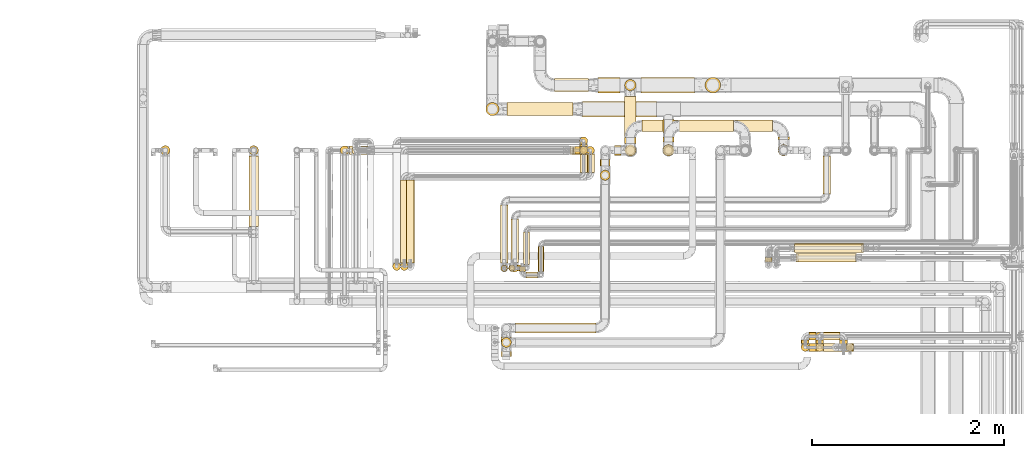
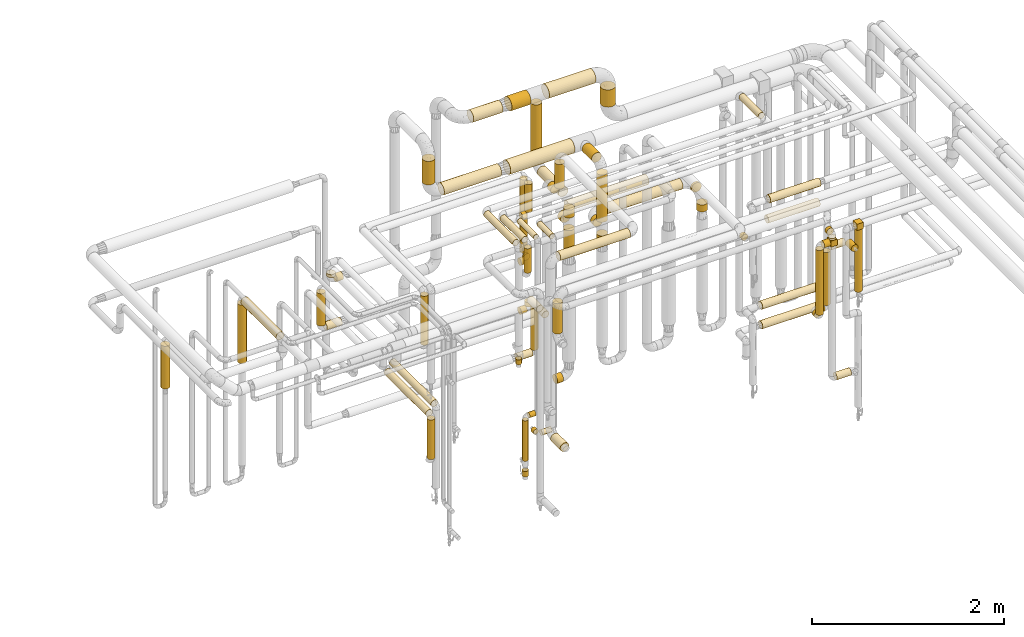
# One storey, part 17 of 824: 78 coverings.
"""IFC2X3 building model written with IfcOpenShell, lengths in millimetres."""

from ifc_helpers import new_model, entity, si_unit, converted_unit, derived_unit, direction, frame, origin, origin_2d_with_axis, place, context, subcontext, project, spatial, rectangle, circle, extrude, element, save


model = new_model("IFC2X3")

# Units and contexts
model_context = context("Model", 3, precision=0.01, world=origin(), true_north=direction((6.12303176911189e-17, 1.0)))
body_context = subcontext(model_context, "Body", "Model", "MODEL_VIEW")
ifc_project = project(units=[si_unit("LENGTHUNIT", "METRE", prefix="MILLI"), si_unit("AREAUNIT", "SQUARE_METRE"), si_unit("VOLUMEUNIT", "CUBIC_METRE"), converted_unit("PLANEANGLEUNIT", "DEGREE", entity("IfcRatioMeasure", 0.0174532925199433), si_unit("PLANEANGLEUNIT", "RADIAN"), dimensions=[0, 0, 0, 0, 0, 0, 0]), si_unit("MASSUNIT", "GRAM", prefix="KILO"), derived_unit("MASSDENSITYUNIT", [(si_unit("MASSUNIT", "GRAM", prefix="KILO"), 1), (si_unit("LENGTHUNIT", "METRE"), -3)]), derived_unit("MOMENTOFINERTIAUNIT", [(si_unit("LENGTHUNIT", "METRE"), 4)]), si_unit("TIMEUNIT", "SECOND"), si_unit("FREQUENCYUNIT", "HERTZ"), si_unit("THERMODYNAMICTEMPERATUREUNIT", "DEGREE_CELSIUS"), derived_unit("THERMALTRANSMITTANCEUNIT", [(si_unit("MASSUNIT", "GRAM", prefix="KILO"), 1), (si_unit("THERMODYNAMICTEMPERATUREUNIT", "KELVIN"), -1), (si_unit("TIMEUNIT", "SECOND"), -3)]), derived_unit("VOLUMETRICFLOWRATEUNIT", [(si_unit("LENGTHUNIT", "METRE"), 3), (si_unit("TIMEUNIT", "SECOND"), -1)]), derived_unit("MASSFLOWRATEUNIT", [(si_unit("MASSUNIT", "GRAM", prefix="KILO"), 1), (si_unit("TIMEUNIT", "SECOND"), -1)]), derived_unit("ROTATIONALFREQUENCYUNIT", [(si_unit("TIMEUNIT", "SECOND"), -1)]), si_unit("ELECTRICCURRENTUNIT", "AMPERE"), si_unit("ELECTRICVOLTAGEUNIT", "VOLT"), si_unit("POWERUNIT", "WATT"), si_unit("FORCEUNIT", "NEWTON", prefix="KILO"), si_unit("ILLUMINANCEUNIT", "LUX"), si_unit("LUMINOUSFLUXUNIT", "LUMEN"), si_unit("LUMINOUSINTENSITYUNIT", "CANDELA"), derived_unit("USERDEFINED", [(si_unit("MASSUNIT", "GRAM", prefix="KILO"), -1), (si_unit("LENGTHUNIT", "METRE"), -2), (si_unit("TIMEUNIT", "SECOND"), 3), (si_unit("LUMINOUSFLUXUNIT", "LUMEN"), 1)]), derived_unit("LINEARVELOCITYUNIT", [(si_unit("LENGTHUNIT", "METRE"), 1), (si_unit("TIMEUNIT", "SECOND"), -1)]), si_unit("PRESSUREUNIT", "PASCAL"), derived_unit("USERDEFINED", [(si_unit("LENGTHUNIT", "METRE"), -2), (si_unit("MASSUNIT", "GRAM", prefix="KILO"), 1), (si_unit("TIMEUNIT", "SECOND"), -2)]), derived_unit("LINEARFORCEUNIT", [(si_unit("MASSUNIT", "GRAM", prefix="KILO"), 1), (si_unit("LENGTHUNIT", "METRE"), 1), (si_unit("TIMEUNIT", "SECOND"), -2), (si_unit("LENGTHUNIT", "METRE"), -1)]), derived_unit("PLANARFORCEUNIT", [(si_unit("MASSUNIT", "GRAM", prefix="KILO"), 1), (si_unit("LENGTHUNIT", "METRE"), 1), (si_unit("TIMEUNIT", "SECOND"), -2), (si_unit("LENGTHUNIT", "METRE"), -2)])], contexts=[model_context])

# Site, building, storey
site_placement = place(None, origin())
site = spatial("IfcSite", under=ifc_project, at=site_placement, CompositionType="ELEMENT")
building_placement = place(site_placement, origin())
building = spatial("IfcBuilding", under=site, at=building_placement, CompositionType="ELEMENT")
storey_placement = place(building_placement, frame((0.0, 0.0, 28200.0)))
storey = spatial("IfcBuildingStorey", under=building, at=storey_placement, CompositionType="ELEMENT", Elevation=28200.0)

# Coverings
covering_1_placement = place(storey_placement, frame((53070.46, 17449.4, 1898.17)))
element("IfcCovering", 1, at=covering_1_placement, inside=storey, PredefinedType="INSULATION", context=body_context, shape_type="SweptSolid", body=[
    extrude(circle(Radius=49.0, at=origin_2d_with_axis()), frame((50.6, 50.6, 0.0), z_axis=(0.0, 0.0, 1.0), x_axis=(-1.0, 0.0, 0.0)), (0.0, 0.0, 1.0), 743.078196918212),
])
covering_2_placement = place(storey_placement, frame((52147.68, 17449.4, 1898.17)))
element("IfcCovering", 2, at=covering_2_placement, inside=storey, PredefinedType="INSULATION", context=body_context, shape_type="SweptSolid", body=[
    extrude(circle(Radius=49.0, at=origin_2d_with_axis()), frame((50.6, 50.6, 0.0), z_axis=(0.0, 0.0, 1.0), x_axis=(-1.0, 0.0, 0.0)), (0.0, 0.0, 1.0), 543.000000000011),
])
covering_3_placement = place(storey_placement, frame((53070.46, 16705.32, 2647.65)))
element("IfcCovering", 3, at=covering_3_placement, inside=storey, PredefinedType="INSULATION", context=body_context, shape_type="SweptSolid", body=[
    extrude(circle(Radius=49.0, at=origin_2d_with_axis()), frame((50.6, 0.07, 51.61), z_axis=(0.0, 0.999999057686602, -0.00137281677839978), x_axis=(1.0, 0.0, 0.0)), (0.0, 0.0, 1.0), 737.692684756272),
])
covering_4_placement = place(storey_placement, frame((57387.04, 17586.0, 2039.15)))
element("IfcCovering", 4, at=covering_4_placement, inside=storey, PredefinedType="INSULATION", context=body_context, shape_type="SweptSolid", body=[
    extrude(circle(Radius=59.25, at=origin_2d_with_axis()), frame((60.85, 0.0, 60.85), z_axis=(0.0, 1.0, 0.0), x_axis=(1.0, 0.0, 0.0)), (0.0, 0.0, 1.0), 55.0961141089978),
])
covering_5_placement = place(storey_placement, frame((57387.04, 17614.0, 2839.12)))
element("IfcCovering", 5, at=covering_5_placement, inside=storey, PredefinedType="INSULATION", context=body_context, shape_type="SweptSolid", body=[
    extrude(circle(Radius=59.25, at=origin_2d_with_axis()), frame((60.85, 0.0, 60.85), z_axis=(0.0, 1.0, 0.0), x_axis=(1.0, 0.0, 0.0)), (0.0, 0.0, 1.0), 205.096097794299),
])
covering_6_placement = place(storey_placement, frame((57387.04, 17439.15, 1915.45)))
element("IfcCovering", 6, at=covering_6_placement, inside=storey, PredefinedType="INSULATION", context=body_context, shape_type="SweptSolid", body=[
    extrude(circle(Radius=59.25, at=origin_2d_with_axis()), frame((60.85, 60.85, 0.0), z_axis=(0.0, 0.0, 1.0), x_axis=(-1.0, 0.0, 0.0)), (0.0, 0.0, 1.0), 98.5472224728106),
])
covering_7_placement = place(storey_placement, frame((57387.04, 17439.15, 2186.0)))
element("IfcCovering", 7, at=covering_7_placement, inside=storey, PredefinedType="INSULATION", context=body_context, shape_type="SweptSolid", body=[
    extrude(circle(Radius=59.25, at=origin_2d_with_axis()), frame((60.85, 60.85, 0.0), z_axis=(0.0, 0.0, 1.0), x_axis=(-1.0, 0.0, 0.0)), (0.0, 0.0, 1.0), 600.000000000011),
])
covering_8_placement = place(storey_placement, frame((58588.54, 17614.0, 2039.15)))
element("IfcCovering", 8, at=covering_8_placement, inside=storey, PredefinedType="INSULATION", context=body_context, shape_type="SweptSolid", body=[
    extrude(circle(Radius=59.25, at=origin_2d_with_axis()), frame((60.85, 0.0, 60.85), z_axis=(0.0, 1.0, 0.0), x_axis=(1.0, 0.0, 0.0)), (0.0, 0.0, 1.0), 27.0961141089868),
])
covering_9_placement = place(storey_placement, frame((58588.54, 17439.15, 1898.17)))
element("IfcCovering", 9, at=covering_9_placement, inside=storey, PredefinedType="INSULATION", context=body_context, shape_type="SweptSolid", body=[
    extrude(circle(Radius=59.25, at=origin_2d_with_axis()), frame((60.85, 60.85, 0.0)), (0.0, 0.0, 1.0), 87.8307333425285),
])
covering_10_placement = place(storey_placement, frame((59297.12, 15400.86, 1868.01)))
element("IfcCovering", 10, at=covering_10_placement, inside=storey, PredefinedType="INSULATION", context=body_context, shape_type="SweptSolid", body=[
    extrude(circle(Radius=41.75, at=origin_2d_with_axis()), frame((43.35, 43.35, 0.0), z_axis=(0.0, 0.0, 1.0), x_axis=(0.0, -1.0, 0.0)), (0.0, 0.0, 1.0), 793.987023342036),
])
covering_11_placement = place(storey_placement, frame((59302.46, 15402.36, 2662.0)))
element("IfcCovering", 11, at=covering_11_placement, inside=storey, PredefinedType="INSULATION", context=body_context, shape_type="SweptSolid", body=[
    extrude(rectangle(XDim=75.9999999999914, YDim=83.7000000000026, at=origin_2d_with_axis()), frame((38.0, 41.85, 0.0)), (0.0, 0.0, 1.0), 79.8499999999992),
])
covering_12_placement = place(storey_placement, frame((58981.79, 15482.21, 2656.65)))
element("IfcCovering", 12, at=covering_12_placement, inside=storey, PredefinedType="INSULATION", context=body_context, shape_type="SweptSolid", body=[
    extrude(circle(Radius=41.75, at=origin_2d_with_axis()), frame((43.35, 0.0, 43.35), z_axis=(0.0, 1.0, 0.0), x_axis=(1.0, 0.0, 0.0)), (0.0, 0.0, 1.0), 40.3142874709578),
])
covering_13_placement = place(storey_placement, frame((59063.14, 15400.86, 827.17)))
element("IfcCovering", 13, at=covering_13_placement, inside=storey, PredefinedType="INSULATION", context=body_context, shape_type="SweptSolid", body=[
    extrude(circle(Radius=41.75, at=origin_2d_with_axis()), frame((0.0, 43.35, 43.35), z_axis=(1.0, 0.0, 0.0), x_axis=(0.0, 1.0, 0.0)), (0.0, 0.0, 1.0), 172.217361032213),
])
covering_14_placement = place(storey_placement, frame((58911.89, 15400.86, 2556.65)))
element("IfcCovering", 14, at=covering_14_placement, inside=storey, PredefinedType="INSULATION", context=body_context, shape_type="SweptSolid", body=[
    extrude(circle(Radius=41.75, at=origin_2d_with_axis()), frame((0.0, 43.35, 43.35), z_axis=(1.0, 0.0, 0.0), x_axis=(0.0, -1.0, 0.0)), (0.0, 0.0, 1.0), 75.2500000000219),
])
covering_15_placement = place(storey_placement, frame((58987.14, 15402.36, 2562.0)))
element("IfcCovering", 15, at=covering_15_placement, inside=storey, PredefinedType="INSULATION", context=body_context, shape_type="SweptSolid", body=[
    extrude(rectangle(XDim=79.8500000000035, YDim=83.7000000000026, at=origin_2d_with_axis()), frame((39.93, 41.85, 0.0)), (0.0, 0.0, 1.0), 75.9999999999957),
])
covering_16_placement = place(storey_placement, frame((58981.79, 15400.86, 2638.0)))
element("IfcCovering", 16, at=covering_16_placement, inside=storey, PredefinedType="INSULATION", context=body_context, shape_type="SweptSolid", body=[
    extrude(circle(Radius=41.75, at=origin_2d_with_axis()), frame((43.35, 43.35, 0.0)), (0.0, 0.0, 1.0), 24.0000000000075),
])
covering_17_placement = place(storey_placement, frame((58830.54, 15400.86, 1738.53)))
element("IfcCovering", 17, at=covering_17_placement, inside=storey, PredefinedType="INSULATION", context=body_context, shape_type="SweptSolid", body=[
    extrude(circle(Radius=41.75, at=origin_2d_with_axis()), frame((43.35, 43.35, 0.0)), (0.0, 0.0, 1.0), 823.470090868733),
])
covering_18_placement = place(storey_placement, frame((58830.54, 15482.21, 1657.18)))
element("IfcCovering", 18, at=covering_18_placement, inside=storey, PredefinedType="INSULATION", context=body_context, shape_type="SweptSolid", body=[
    extrude(circle(Radius=41.75, at=origin_2d_with_axis()), frame((43.35, 0.0, 43.35), z_axis=(0.0, 1.0, 0.0), x_axis=(-1.0, 0.0, 0.0)), (0.0, 0.0, 1.0), 40.2592236656059),
])
covering_19_placement = place(storey_placement, frame((58911.89, 15517.12, 1657.18)))
element("IfcCovering", 19, at=covering_19_placement, inside=storey, PredefinedType="INSULATION", context=body_context, shape_type="SweptSolid", body=[
    extrude(circle(Radius=41.75, at=origin_2d_with_axis()), frame((0.0, 43.35, 43.35), z_axis=(1.0, 0.0, 0.0), x_axis=(0.0, 1.0, 0.0)), (0.0, 0.0, 1.0), 74.0000000000178),
])
covering_20_placement = place(storey_placement, frame((58980.54, 15517.12, 1738.53)))
element("IfcCovering", 20, at=covering_20_placement, inside=storey, PredefinedType="INSULATION", context=body_context, shape_type="SweptSolid", body=[
    extrude(circle(Radius=41.75, at=origin_2d_with_axis()), frame((43.35, 43.35, 0.0), z_axis=(0.0, 0.0, 1.0), x_axis=(0.0, 1.0, 0.0)), (0.0, 0.0, 1.0), 674.000039895076),
])
covering_21_placement = place(storey_placement, frame((59061.89, 15517.18, 2407.18)))
element("IfcCovering", 21, at=covering_21_placement, inside=storey, PredefinedType="INSULATION", context=body_context, shape_type="SweptSolid", body=[
    extrude(circle(Radius=41.75, at=origin_2d_with_axis()), frame((0.0, 43.35, 43.35), z_axis=(1.0, 0.0, 0.0), x_axis=(0.0, 1.0, 0.0)), (0.0, 0.0, 1.0), 173.467361032217),
])
covering_22_placement = place(storey_placement, frame((59230.01, 15402.52, 2407.18)))
element("IfcCovering", 22, at=covering_22_placement, inside=storey, PredefinedType="INSULATION", context=body_context, shape_type="SweptSolid", body=[
    extrude(circle(Radius=41.75, at=origin_2d_with_axis()), frame((43.35, 0.0, 43.35), z_axis=(0.0, 1.0, 0.0), x_axis=(1.0, 0.0, 0.0)), (0.0, 0.0, 1.0), 119.99999999999),
])
covering_23_placement = place(storey_placement, frame((56551.05, 17847.0, 2816.87)))
element("IfcCovering", 23, at=covering_23_placement, inside=storey, PredefinedType="INSULATION", context=body_context, shape_type="SweptSolid", body=[
    extrude(circle(Radius=81.5, at=origin_2d_with_axis()), frame((0.0, 83.1, 83.1), z_axis=(1.0, 0.0, 0.0), x_axis=(0.0, -1.0, 0.0)), (0.0, 0.0, 1.0), 772.836562103827),
])
covering_24_placement = place(storey_placement, frame((55761.05, 17859.5, 2829.37)))
element("IfcCovering", 24, at=covering_24_placement, inside=storey, PredefinedType="INSULATION", context=body_context, shape_type="SweptSolid", body=[
    extrude(circle(Radius=69.0, at=origin_2d_with_axis()), frame((0.0, 70.6, 70.6), z_axis=(1.0, 0.0, 0.0), x_axis=(0.0, -1.0, 0.0)), (0.0, 0.0, 1.0), 690.000000000068),
])
covering_25_placement = place(storey_placement, frame((55540.45, 17859.5, 3049.96)))
element("IfcCovering", 25, at=covering_25_placement, inside=storey, PredefinedType="INSULATION", context=body_context, shape_type="SweptSolid", body=[
    extrude(circle(Radius=69.0, at=origin_2d_with_axis()), frame((70.6, 70.6, 0.0), z_axis=(0.0, 0.0, 1.0), x_axis=(0.0, -1.0, 0.0)), (0.0, 0.0, 1.0), 299.782089013241),
])
covering_26_placement = place(storey_placement, frame((57561.89, 17694.25, 2039.15)))
element("IfcCovering", 26, at=covering_26_placement, inside=storey, PredefinedType="INSULATION", context=body_context, shape_type="SweptSolid", body=[
    extrude(circle(Radius=59.25, at=origin_2d_with_axis()), frame((0.0, 60.85, 60.85), z_axis=(1.0, 0.0, 0.0), x_axis=(0.0, 1.0, 0.0)), (0.0, 0.0, 1.0), 973.496500000027),
])
covering_27_placement = place(storey_placement, frame((56519.88, 17456.65, 2605.5)))
element("IfcCovering", 27, at=covering_27_placement, inside=storey, PredefinedType="INSULATION", context=body_context, shape_type="SweptSolid", body=[
    extrude(circle(Radius=41.75, at=origin_2d_with_axis()), frame((43.35, 43.35, 0.0), z_axis=(0.0, 0.0, 1.0), x_axis=(0.0, -1.0, 0.0)), (0.0, 0.0, 1.0), 356.499999999793),
])
covering_28_placement = place(storey_placement, frame((56472.19, 17456.65, 2524.15)))
element("IfcCovering", 28, at=covering_28_placement, inside=storey, PredefinedType="INSULATION", context=body_context, shape_type="SweptSolid", body=[
    extrude(circle(Radius=41.75, at=origin_2d_with_axis()), frame((0.0, 43.35, 43.35), z_axis=(1.0, 0.0, 0.0), x_axis=(0.0, -1.0, 0.0)), (0.0, 0.0, 1.0), 53.0388803778343),
])
covering_29_placement = place(storey_placement, frame((54142.04, 17452.25, 2615.5)))
element("IfcCovering", 29, at=covering_29_placement, inside=storey, PredefinedType="INSULATION", context=body_context, shape_type="SweptSolid", body=[
    extrude(circle(Radius=46.15, at=origin_2d_with_axis()), frame((47.75, 47.75, 0.0), z_axis=(0.0, 0.0, 1.0), x_axis=(-1.0, 0.0, 0.0)), (0.0, 0.0, 1.0), 36.4999999999354),
])
covering_30_placement = place(storey_placement, frame((54237.79, 17452.25, 2519.75)))
element("IfcCovering", 30, at=covering_30_placement, inside=storey, PredefinedType="INSULATION", context=body_context, shape_type="SweptSolid", body=[
    extrude(circle(Radius=46.15, at=origin_2d_with_axis()), frame((0.0, 47.75, 47.75), z_axis=(1.0, 0.0, 0.0), x_axis=(0.0, 1.0, 0.0)), (0.0, 0.0, 1.0), 77.0000000000172),
])
covering_31_placement = place(storey_placement, frame((54568.84, 16245.22, 2338.09)))
element("IfcCovering", 31, at=covering_31_placement, inside=storey, PredefinedType="INSULATION", context=body_context, shape_type="SweptSolid", body=[
    extrude(circle(Radius=41.75, at=origin_2d_with_axis()), frame((43.35, 43.35, 0.0)), (0.0, 0.0, 1.0), 624.000000000014),
])
covering_32_placement = place(storey_placement, frame((56519.88, 17555.47, 2030.5)))
element("IfcCovering", 32, at=covering_32_placement, inside=storey, PredefinedType="INSULATION", context=body_context, shape_type="SweptSolid", body=[
    extrude(circle(Radius=41.75, at=origin_2d_with_axis()), frame((43.35, 43.35, 0.0)), (0.0, 0.0, 1.0), 931.586150798507),
])
covering_33_placement = place(storey_placement, frame((56519.88, 17538.0, 1949.15)))
element("IfcCovering", 33, at=covering_33_placement, inside=storey, PredefinedType="INSULATION", context=body_context, shape_type="SweptSolid", body=[
    extrude(circle(Radius=41.75, at=origin_2d_with_axis()), frame((43.35, 0.0, 43.35), z_axis=(0.0, 1.0, 0.0), x_axis=(1.0, 0.0, 0.0)), (0.0, 0.0, 1.0), 22.8207544577575),
])
covering_34_placement = place(storey_placement, frame((56454.69, 17456.65, 1949.15)))
element("IfcCovering", 34, at=covering_34_placement, inside=storey, PredefinedType="INSULATION", context=body_context, shape_type="SweptSolid", body=[
    extrude(circle(Radius=41.75, at=origin_2d_with_axis()), frame((0.0, 43.35, 43.35), z_axis=(1.0, 0.0, 0.0), x_axis=(0.0, -1.0, 0.0)), (0.0, 0.0, 1.0), 70.5388803777957),
])
covering_35_placement = place(storey_placement, frame((54022.04, 17452.25, 2040.5)))
element("IfcCovering", 35, at=covering_35_placement, inside=storey, PredefinedType="INSULATION", context=body_context, shape_type="SweptSolid", body=[
    extrude(circle(Radius=46.15, at=origin_2d_with_axis()), frame((47.75, 47.75, 0.0), z_axis=(0.0, 0.0, 1.0), x_axis=(-1.0, 0.0, 0.0)), (0.0, 0.0, 1.0), 411.500000000015),
])
covering_36_placement = place(storey_placement, frame((54117.79, 17452.25, 1944.75)))
element("IfcCovering", 36, at=covering_36_placement, inside=storey, PredefinedType="INSULATION", context=body_context, shape_type="SweptSolid", body=[
    extrude(circle(Radius=46.15, at=origin_2d_with_axis()), frame((0.0, 47.75, 47.75), z_axis=(1.0, 0.0, 0.0), x_axis=(0.0, 1.0, 0.0)), (0.0, 0.0, 1.0), 182.000000000011),
])
covering_37_placement = place(storey_placement, frame((54648.84, 16326.56, 1356.65)))
element("IfcCovering", 37, at=covering_37_placement, inside=storey, PredefinedType="INSULATION", context=body_context, shape_type="SweptSolid", body=[
    extrude(circle(Radius=41.75, at=origin_2d_with_axis()), frame((43.35, 0.0, 43.35), z_axis=(0.0, 1.0, 0.0), x_axis=(1.0, 0.0, 0.0)), (0.0, 0.0, 1.0), 864.000000000016),
])
covering_38_placement = place(storey_placement, frame((54648.84, 16245.22, 858.0)))
element("IfcCovering", 38, at=covering_38_placement, inside=storey, PredefinedType="INSULATION", context=body_context, shape_type="SweptSolid", body=[
    extrude(circle(Radius=41.75, at=origin_2d_with_axis()), frame((43.35, 43.35, 0.0), z_axis=(0.0, 0.0, 1.0), x_axis=(-1.0, 0.0, 0.0)), (0.0, 0.0, 1.0), 504.000000000015),
])
covering_39_placement = place(storey_placement, frame((56589.88, 17266.56, 1356.65)))
element("IfcCovering", 39, at=covering_39_placement, inside=storey, PredefinedType="INSULATION", context=body_context, shape_type="SweptSolid", body=[
    extrude(circle(Radius=41.75, at=origin_2d_with_axis()), frame((43.35, 0.0, 43.35), z_axis=(0.0, 1.0, 0.0), x_axis=(-1.0, 0.0, 0.0)), (0.0, 0.0, 1.0), 195.438135542264),
])
covering_40_placement = place(storey_placement, frame((56589.88, 17456.65, 830.5)))
element("IfcCovering", 40, at=covering_40_placement, inside=storey, PredefinedType="INSULATION", context=body_context, shape_type="SweptSolid", body=[
    extrude(circle(Radius=41.75, at=origin_2d_with_axis()), frame((43.35, 43.35, 0.0), z_axis=(0.0, 0.0, 1.0), x_axis=(-1.0, 0.0, 0.0)), (0.0, 0.0, 1.0), 531.500000000009),
])
covering_41_placement = place(storey_placement, frame((56418.23, 17456.65, 749.15)))
element("IfcCovering", 41, at=covering_41_placement, inside=storey, PredefinedType="INSULATION", context=body_context, shape_type="SweptSolid", body=[
    extrude(circle(Radius=41.75, at=origin_2d_with_axis()), frame((0.0, 43.35, 43.35), z_axis=(1.0, 0.0, 0.0), x_axis=(0.0, -1.0, 0.0)), (0.0, 0.0, 1.0), 177.00000000002),
])
covering_42_placement = place(storey_placement, frame((56520.88, 17266.56, 1456.65)))
element("IfcCovering", 42, at=covering_42_placement, inside=storey, PredefinedType="INSULATION", context=body_context, shape_type="SweptSolid", body=[
    extrude(circle(Radius=41.75, at=origin_2d_with_axis()), frame((43.35, 0.0, 43.35), z_axis=(0.0, 1.0, 0.0), x_axis=(-1.0, 0.0, 0.0)), (0.0, 0.0, 1.0), 195.438135542264),
])
covering_43_placement = place(storey_placement, frame((54710.88, 16326.56, 1456.65)))
element("IfcCovering", 43, at=covering_43_placement, inside=storey, PredefinedType="INSULATION", context=body_context, shape_type="SweptSolid", body=[
    extrude(circle(Radius=41.75, at=origin_2d_with_axis()), frame((43.35, 0.0, 43.35), z_axis=(0.0, 1.0, 0.0), x_axis=(1.0, 0.0, 0.0)), (0.0, 0.0, 1.0), 864.000000000014),
])
covering_44_placement = place(storey_placement, frame((56454.23, 17456.65, 1326.65)))
element("IfcCovering", 44, at=covering_44_placement, inside=storey, PredefinedType="INSULATION", context=body_context, shape_type="SweptSolid", body=[
    extrude(circle(Radius=41.75, at=origin_2d_with_axis()), frame((0.0, 43.35, 43.35), z_axis=(1.0, 0.0, 0.0), x_axis=(0.0, -1.0, 0.0)), (0.0, 0.0, 1.0), 72.0000000000269),
])
covering_45_placement = place(storey_placement, frame((56520.88, 17456.65, 1408.0)))
element("IfcCovering", 45, at=covering_45_placement, inside=storey, PredefinedType="INSULATION", context=body_context, shape_type="SweptSolid", body=[
    extrude(circle(Radius=41.75, at=origin_2d_with_axis()), frame((43.35, 43.35, 0.0), z_axis=(0.0, 0.0, 1.0), x_axis=(0.0, 1.0, 0.0)), (0.0, 0.0, 1.0), 54.0000000000224),
])
covering_46_placement = place(storey_placement, frame((55802.54, 16327.44, 3159.4)))
element("IfcCovering", 46, at=covering_46_placement, inside=storey, PredefinedType="INSULATION", context=body_context, shape_type="SweptSolid", body=[
    extrude(circle(Radius=39.0, at=origin_2d_with_axis()), frame((40.6, 0.0, 40.6), z_axis=(0.0, 1.0, 0.0), x_axis=(1.0, 0.0, 0.0)), (0.0, 0.0, 1.0), 453.499999999986),
])
covering_47_placement = place(storey_placement, frame((55802.54, 16229.84, 2832.0)))
element("IfcCovering", 47, at=covering_47_placement, inside=storey, PredefinedType="INSULATION", context=body_context, shape_type="SweptSolid", body=[
    extrude(circle(Radius=39.0, at=origin_2d_with_axis()), frame((40.6, 40.6, 0.0), z_axis=(0.0, 0.0, 1.0), x_axis=(-1.0, 0.0, 0.0)), (0.0, 0.0, 1.0), 310.999999999973),
])
covering_48_placement = place(storey_placement, frame((56084.79, 16235.94, 3166.65)))
element("IfcCovering", 48, at=covering_48_placement, inside=storey, PredefinedType="INSULATION", context=body_context, shape_type="SweptSolid", body=[
    extrude(circle(Radius=31.75, at=origin_2d_with_axis()), frame((33.35, 0.0, 33.35), z_axis=(0.0, 1.0, 0.0), x_axis=(1.0, 0.0, 0.0)), (0.0, 0.0, 1.0), 261.759412695868),
])
covering_49_placement = place(storey_placement, frame((55961.13, 16164.59, 751.4)))
element("IfcCovering", 49, at=covering_49_placement, inside=storey, PredefinedType="INSULATION", context=body_context, shape_type="SweptSolid", body=[
    extrude(circle(Radius=31.75, at=origin_2d_with_axis()), frame((0.0, 33.35, 33.35), z_axis=(1.0, 0.0, 0.0), x_axis=(0.0, -1.0, 0.0)), (0.0, 0.0, 1.0), 119.000000000016),
])
covering_50_placement = place(storey_placement, frame((55889.79, 16235.94, 751.4)))
element("IfcCovering", 50, at=covering_50_placement, inside=storey, PredefinedType="INSULATION", context=body_context, shape_type="SweptSolid", body=[
    extrude(circle(Radius=31.75, at=origin_2d_with_axis()), frame((33.35, 0.0, 33.35), z_axis=(0.0, 1.0, 0.0), x_axis=(-1.0, 0.0, 0.0)), (0.0, 0.0, 1.0), 49.9999999999995),
])
covering_51_placement = place(storey_placement, frame((58801.1, 16332.09, 2602.25)))
element("IfcCovering", 51, at=covering_51_placement, inside=storey, PredefinedType="INSULATION", context=body_context, shape_type="SweptSolid", body=[
    extrude(circle(Radius=46.15, at=origin_2d_with_axis()), frame((0.0, 47.75, 47.75), z_axis=(1.0, 0.0, 0.0), x_axis=(0.0, 1.0, 0.0)), (0.0, 0.0, 1.0), 608.330451835312),
])
covering_52_placement = place(storey_placement, frame((58451.15, 16333.94, 2254.95)))
element("IfcCovering", 52, at=covering_52_placement, inside=storey, PredefinedType="INSULATION", context=body_context, shape_type="SweptSolid", body=[
    extrude(circle(Radius=38.45, at=origin_2d_with_axis()), frame((40.05, 0.0, 40.05), z_axis=(0.0, 1.0, 0.0), x_axis=(0.0, 0.0, 1.0)), (0.0, 0.0, 1.0), 49.9999999999995),
])
covering_53_placement = place(storey_placement, frame((58778.82, 16332.09, 2352.25)))
element("IfcCovering", 53, at=covering_53_placement, inside=storey, PredefinedType="INSULATION", context=body_context, shape_type="SweptSolid", body=[
    extrude(circle(Radius=46.15, at=origin_2d_with_axis()), frame((0.0, 47.75, 47.75), z_axis=(1.0, 0.0, 0.0), x_axis=(0.0, -1.0, 0.0)), (0.0, 0.0, 1.0), 620.000000000006),
])
covering_54_placement = place(storey_placement, frame((58764.02, 16431.91, 1202.25)))
element("IfcCovering", 54, at=covering_54_placement, inside=storey, PredefinedType="INSULATION", context=body_context, shape_type="SweptSolid", body=[
    extrude(circle(Radius=46.15, at=origin_2d_with_axis()), frame((0.0, 47.75, 47.75), z_axis=(1.0, 0.0, 0.0), x_axis=(0.0, 1.0, 0.0)), (0.0, 0.0, 1.0), 698.842962557812),
])
covering_55_placement = place(storey_placement, frame((58764.02, 16431.48, 952.25)))
element("IfcCovering", 55, at=covering_55_placement, inside=storey, PredefinedType="INSULATION", context=body_context, shape_type="SweptSolid", body=[
    extrude(circle(Radius=46.15, at=origin_2d_with_axis()), frame((0.0, 47.75, 47.75), z_axis=(1.0, 0.0, 6.7602214637812e-06), x_axis=(0.0, -1.0, 0.0)), (0.0, 0.0, 1.0), 717.619049674226),
])
covering_56_placement = place(storey_placement, frame((57827.95, 18097.0, 3090.0)))
element("IfcCovering", 56, at=covering_56_placement, inside=storey, PredefinedType="INSULATION", context=body_context, shape_type="SweptSolid", body=[
    extrude(circle(Radius=81.5, at=origin_2d_with_axis()), frame((83.1, 83.1, 0.0), z_axis=(0.0, 0.0, 1.0), x_axis=(-1.0, 0.0, 0.0)), (0.0, 0.0, 1.0), 219.743188805708),
])
covering_57_placement = place(storey_placement, frame((56711.05, 18097.0, 3416.65)))
element("IfcCovering", 57, at=covering_57_placement, inside=storey, PredefinedType="INSULATION", context=body_context, shape_type="SweptSolid", body=[
    extrude(circle(Radius=81.5, at=origin_2d_with_axis()), frame((0.0, 83.1, 83.1), z_axis=(1.0, 0.0, 0.0), x_axis=(0.0, -1.0, 0.0)), (0.0, 0.0, 1.0), 229.02119087204),
])
covering_58_placement = place(storey_placement, frame((56258.55, 18109.5, 3429.15)))
element("IfcCovering", 58, at=covering_58_placement, inside=storey, PredefinedType="INSULATION", context=body_context, shape_type="SweptSolid", body=[
    extrude(circle(Radius=69.0, at=origin_2d_with_axis()), frame((0.0, 70.6, 70.6), z_axis=(1.0, 0.0, 0.0), x_axis=(0.0, -1.0, 0.0)), (0.0, 0.0, 1.0), 352.499999999972),
])
covering_59_placement = place(storey_placement, frame((56989.22, 18119.25, 2719.74)))
element("IfcCovering", 59, at=covering_59_placement, inside=storey, PredefinedType="INSULATION", context=body_context, shape_type="SweptSolid", body=[
    extrude(circle(Radius=59.25, at=origin_2d_with_axis()), frame((60.85, 60.85, 0.0)), (0.0, 0.0, 1.0), 684.999999999996),
])
covering_60_placement = place(storey_placement, frame((57160.07, 18097.0, 3416.65)))
element("IfcCovering", 60, at=covering_60_placement, inside=storey, PredefinedType="INSULATION", context=body_context, shape_type="SweptSolid", body=[
    extrude(circle(Radius=81.5, at=origin_2d_with_axis()), frame((0.0, 83.1, 83.1), z_axis=(1.0, 0.0, 0.0), x_axis=(0.0, -1.0, 0.0)), (0.0, 0.0, 1.0), 560.978809127979),
])
covering_61_placement = place(storey_placement, frame((56989.22, 17620.0, 2539.15)))
element("IfcCovering", 61, at=covering_61_placement, inside=storey, PredefinedType="INSULATION", context=body_context, shape_type="SweptSolid", body=[
    extrude(circle(Radius=59.25, at=origin_2d_with_axis()), frame((60.85, 0.0, 60.85), z_axis=(0.0, 1.0, 0.0), x_axis=(1.0, 0.0, 0.0)), (0.0, 0.0, 1.0), 440.096114108995),
])
covering_62_placement = place(storey_placement, frame((56989.22, 17439.15, 1892.74)))
element("IfcCovering", 62, at=covering_62_placement, inside=storey, PredefinedType="INSULATION", context=body_context, shape_type="SweptSolid", body=[
    extrude(circle(Radius=59.25, at=origin_2d_with_axis()), frame((60.85, 60.85, 0.0), z_axis=(0.0, 0.0, 1.0), x_axis=(0.0, 1.0, 0.0)), (0.0, 0.0, 1.0), 327.256811194285),
])
covering_63_placement = place(storey_placement, frame((56989.22, 17570.0, 2239.15)))
element("IfcCovering", 63, at=covering_63_placement, inside=storey, PredefinedType="INSULATION", context=body_context, shape_type="SweptSolid", body=[
    extrude(circle(Radius=59.25, at=origin_2d_with_axis()), frame((60.85, 0.0, 60.85), z_axis=(0.0, 1.0, 0.0), x_axis=(-1.0, 0.0, 0.0)), (0.0, 0.0, 1.0), 65.096114108989),
])
covering_64_placement = place(storey_placement, frame((56989.22, 17439.15, 2380.0)))
element("IfcCovering", 64, at=covering_64_placement, inside=storey, PredefinedType="INSULATION", context=body_context, shape_type="SweptSolid", body=[
    extrude(circle(Radius=59.25, at=origin_2d_with_axis()), frame((60.85, 60.85, 0.0), z_axis=(0.0, 0.0, 1.0), x_axis=(0.0, 1.0, 0.0)), (0.0, 0.0, 1.0), 99.7431888057308),
])
covering_65_placement = place(storey_placement, frame((57170.07, 17694.25, 2239.15)))
element("IfcCovering", 65, at=covering_65_placement, inside=storey, PredefinedType="INSULATION", context=body_context, shape_type="SweptSolid", body=[
    extrude(circle(Radius=59.25, at=origin_2d_with_axis()), frame((0.0, 60.85, 60.85), z_axis=(1.0, 0.0, 0.0), x_axis=(0.0, 1.0, 0.0)), (0.0, 0.0, 1.0), 957.500000000025),
])
covering_66_placement = place(storey_placement, frame((56882.39, 17445.65, 298.15)))
element("IfcCovering", 66, at=covering_66_placement, inside=storey, PredefinedType="INSULATION", context=body_context, shape_type="SweptSolid", body=[
    extrude(circle(Radius=52.75, at=origin_2d_with_axis()), frame((0.0, 54.35, 54.35), z_axis=(1.0, 0.0, 0.0), x_axis=(0.0, 1.0, 0.0)), (0.0, 0.0, 1.0), 72.6845769329567),
])
covering_67_placement = place(storey_placement, frame((55932.01, 16308.44, 3166.65)))
element("IfcCovering", 67, at=covering_67_placement, inside=storey, PredefinedType="INSULATION", context=body_context, shape_type="SweptSolid", body=[
    extrude(circle(Radius=31.75, at=origin_2d_with_axis()), frame((33.35, 0.0, 33.35), z_axis=(0.0, 1.0, 0.0), x_axis=(1.0, 0.0, 0.0)), (0.0, 0.0, 1.0), 339.25941269584),
])
covering_68_placement = place(storey_placement, frame((59057.54, 17042.69, 3159.4)))
element("IfcCovering", 68, at=covering_68_placement, inside=storey, PredefinedType="INSULATION", context=body_context, shape_type="SweptSolid", body=[
    extrude(circle(Radius=39.0, at=origin_2d_with_axis()), frame((40.6, 0.0, 40.6), z_axis=(0.0, 1.0, 0.0), x_axis=(1.0, 0.0, 0.0)), (0.0, 0.0, 1.0), 400.304686356029),
])
covering_69_placement = place(storey_placement, frame((55693.58, 16324.94, 3159.4)))
element("IfcCovering", 69, at=covering_69_placement, inside=storey, PredefinedType="INSULATION", context=body_context, shape_type="SweptSolid", body=[
    extrude(circle(Radius=39.0, at=origin_2d_with_axis()), frame((40.6, 0.0, 40.6), z_axis=(0.0, 1.0, 0.0), x_axis=(1.0, 0.0, 0.0)), (0.0, 0.0, 1.0), 603.75941269586),
])
covering_70_placement = place(storey_placement, frame((55850.84, 15591.86, 3345.65)))
element("IfcCovering", 70, at=covering_70_placement, inside=storey, PredefinedType="INSULATION", context=body_context, shape_type="SweptSolid", body=[
    extrude(circle(Radius=52.75, at=origin_2d_with_axis()), frame((0.0, 54.35, 54.35), z_axis=(1.0, 0.0, 0.0), x_axis=(0.0, -1.0, 0.0)), (0.0, 0.0, 1.0), 841.541968197392),
])
covering_71_placement = place(storey_placement, frame((55853.36, 16237.09, 966.65)))
element("IfcCovering", 71, at=covering_71_placement, inside=storey, PredefinedType="INSULATION", context=body_context, shape_type="SweptSolid", body=[
    extrude(circle(Radius=31.75, at=origin_2d_with_axis()), frame((0.0, 33.35, 33.35), z_axis=(1.0, 0.0, 0.0), x_axis=(0.0, -1.0, 0.0)), (0.0, 0.0, 1.0), 74.0000000000178),
])
covering_72_placement = place(storey_placement, frame((55782.01, 16237.09, 446.5)))
element("IfcCovering", 72, at=covering_72_placement, inside=storey, PredefinedType="INSULATION", context=body_context, shape_type="SweptSolid", body=[
    extrude(circle(Radius=31.75, at=origin_2d_with_axis()), frame((33.35, 33.35, 0.0), z_axis=(0.0, 0.0, 1.0), x_axis=(0.0, -1.0, 0.0)), (0.0, 0.0, 1.0), 515.500000000004),
])
covering_73_placement = place(storey_placement, frame((55701.5, 15351.2, 1130.65)))
element("IfcCovering", 73, at=covering_73_placement, inside=storey, PredefinedType="INSULATION", context=body_context, shape_type="SweptSolid", body=[
    extrude(circle(Radius=52.75, at=origin_2d_with_axis()), frame((54.35, 0.0, 54.35), z_axis=(0.0, 1.0, 0.0), x_axis=(1.0, 0.0, 0.0)), (0.0, 0.0, 1.0), 200.000000000009),
])
covering_74_placement = place(storey_placement, frame((55701.5, 15441.86, 2570.0)))
element("IfcCovering", 74, at=covering_74_placement, inside=storey, PredefinedType="INSULATION", context=body_context, shape_type="SweptSolid", body=[
    extrude(circle(Radius=52.75, at=origin_2d_with_axis()), frame((54.35, 54.35, 0.0), z_axis=(0.0, 0.0, 1.0), x_axis=(0.0, -1.0, 0.0)), (0.0, 0.0, 1.0), 384.999999999969),
])
covering_75_placement = place(storey_placement, frame((55778.76, 16233.84, 249.5)))
element("IfcCovering", 75, at=covering_75_placement, inside=storey, PredefinedType="INSULATION", context=body_context, shape_type="SweptSolid", body=[
    extrude(circle(Radius=35.0, at=origin_2d_with_axis()), frame((36.6, 36.6, 0.0), z_axis=(0.0, 0.0, 1.0), x_axis=(0.0, -1.0, 0.0)), (0.0, 0.0, 1.0), 70.0000000000014),
])
covering_76_placement = place(storey_placement, frame((55700.08, 16233.84, 1704.16)))
element("IfcCovering", 76, at=covering_76_placement, inside=storey, PredefinedType="INSULATION", context=body_context, shape_type="SweptSolid", body=[
    extrude(circle(Radius=32.5, at=origin_2d_with_axis()), frame((34.1, 34.1, 0.0), z_axis=(0.0, 0.0, 1.0), x_axis=(0.0, 1.0, 0.0)), (0.0, 0.0, 1.0), 61.0000000000035),
])
covering_77_placement = place(storey_placement, frame((56733.04, 17335.0, 2845.65)))
element("IfcCovering", 77, at=covering_77_placement, inside=storey, PredefinedType="INSULATION", context=body_context, shape_type="SweptSolid", body=[
    extrude(circle(Radius=52.75, at=origin_2d_with_axis()), frame((54.35, 0.0, 54.35), z_axis=(0.0, 1.0, 0.0), x_axis=(-1.0, 0.0, 0.0)), (0.0, 0.0, 1.0), 70.0000000000187),
])
covering_78_placement = place(storey_placement, frame((56733.04, 17185.65, 2995.0)))
element("IfcCovering", 78, at=covering_78_placement, inside=storey, PredefinedType="INSULATION", context=body_context, shape_type="SweptSolid", body=[
    extrude(circle(Radius=52.75, at=origin_2d_with_axis()), frame((54.35, 54.35, 0.0)), (0.0, 0.0, 1.0), 309.999999999999),
])

save(model, "model.ifc")
